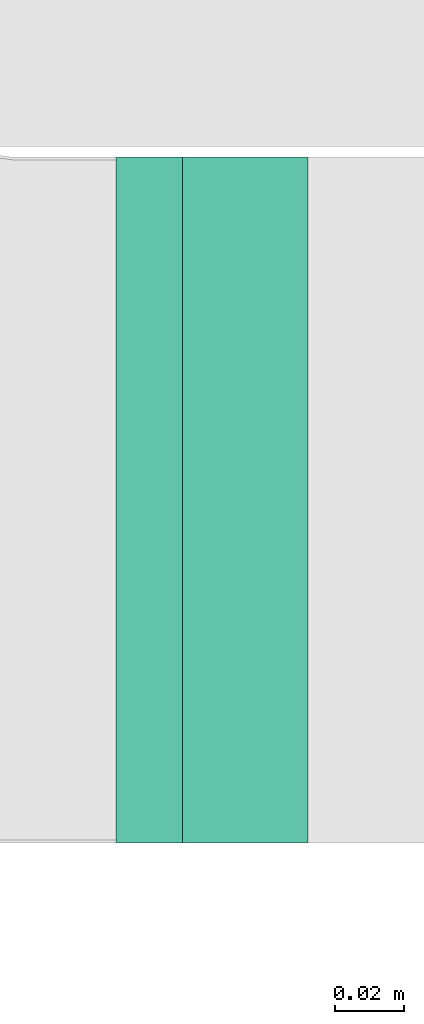
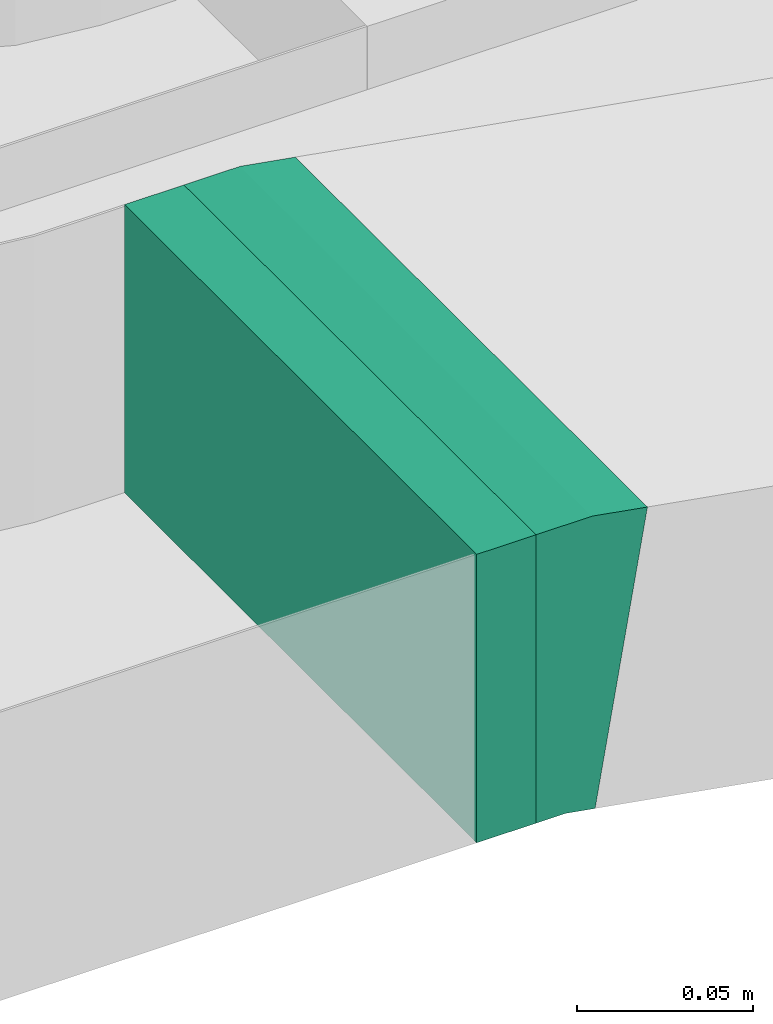
# One storey, part 14 of 38: 1 flow fitting, 1 flow segment.
"""IFC2X3 building model written with IfcOpenShell, lengths in millimetres."""

from ifc_helpers import new_model, entity, si_unit, converted_unit, derived_unit, direction, frame, frame_2d, origin, place, context, subcontext, project, spatial, rectangle, extrude, faceted_brep, source, transform, mapped, material, type_object, type_shapes, element, save


model = new_model("IFC2X3")

# Units and contexts
model_context = context("Model", 3, precision=0.01, world=origin(), true_north=direction((6.12303176911189e-17, 1.0)))
body_context = subcontext(model_context, "Body", "Model", "MODEL_VIEW")
ifc_project = project(units=[si_unit("LENGTHUNIT", "METRE", prefix="MILLI"), si_unit("AREAUNIT", "SQUARE_METRE"), si_unit("VOLUMEUNIT", "CUBIC_METRE"), converted_unit("PLANEANGLEUNIT", "DEGREE", entity("IfcRatioMeasure", 0.0174532925199433), si_unit("PLANEANGLEUNIT", "RADIAN"), dimensions=[0, 0, 0, 0, 0, 0, 0]), si_unit("MASSUNIT", "GRAM", prefix="KILO"), derived_unit("MASSDENSITYUNIT", [(si_unit("MASSUNIT", "GRAM", prefix="KILO"), 1), (si_unit("LENGTHUNIT", "METRE"), -3)]), derived_unit("MOMENTOFINERTIAUNIT", [(si_unit("LENGTHUNIT", "METRE"), 4)]), si_unit("TIMEUNIT", "SECOND"), si_unit("FREQUENCYUNIT", "HERTZ"), si_unit("THERMODYNAMICTEMPERATUREUNIT", "DEGREE_CELSIUS"), derived_unit("THERMALTRANSMITTANCEUNIT", [(si_unit("MASSUNIT", "GRAM", prefix="KILO"), 1), (si_unit("THERMODYNAMICTEMPERATUREUNIT", "KELVIN"), -1), (si_unit("TIMEUNIT", "SECOND"), -3)]), derived_unit("VOLUMETRICFLOWRATEUNIT", [(si_unit("LENGTHUNIT", "METRE"), 3), (si_unit("TIMEUNIT", "SECOND"), -1)]), derived_unit("MASSFLOWRATEUNIT", [(si_unit("MASSUNIT", "GRAM", prefix="KILO"), 1), (si_unit("TIMEUNIT", "SECOND"), -1)]), derived_unit("ROTATIONALFREQUENCYUNIT", [(si_unit("TIMEUNIT", "SECOND"), -1)]), si_unit("ELECTRICCURRENTUNIT", "AMPERE"), si_unit("ELECTRICVOLTAGEUNIT", "VOLT"), si_unit("POWERUNIT", "WATT"), si_unit("FORCEUNIT", "NEWTON", prefix="KILO"), si_unit("ILLUMINANCEUNIT", "LUX"), si_unit("LUMINOUSFLUXUNIT", "LUMEN"), si_unit("LUMINOUSINTENSITYUNIT", "CANDELA"), derived_unit("USERDEFINED", [(si_unit("MASSUNIT", "GRAM", prefix="KILO"), -1), (si_unit("LENGTHUNIT", "METRE"), -2), (si_unit("TIMEUNIT", "SECOND"), 3), (si_unit("LUMINOUSFLUXUNIT", "LUMEN"), 1)]), derived_unit("LINEARVELOCITYUNIT", [(si_unit("LENGTHUNIT", "METRE"), 1), (si_unit("TIMEUNIT", "SECOND"), -1)]), si_unit("PRESSUREUNIT", "PASCAL"), derived_unit("USERDEFINED", [(si_unit("LENGTHUNIT", "METRE"), -2), (si_unit("MASSUNIT", "GRAM", prefix="KILO"), 1), (si_unit("TIMEUNIT", "SECOND"), -2)]), derived_unit("LINEARFORCEUNIT", [(si_unit("MASSUNIT", "GRAM", prefix="KILO"), 1), (si_unit("LENGTHUNIT", "METRE"), 1), (si_unit("TIMEUNIT", "SECOND"), -2), (si_unit("LENGTHUNIT", "METRE"), -1)]), derived_unit("PLANARFORCEUNIT", [(si_unit("MASSUNIT", "GRAM", prefix="KILO"), 1), (si_unit("LENGTHUNIT", "METRE"), 1), (si_unit("TIMEUNIT", "SECOND"), -2), (si_unit("LENGTHUNIT", "METRE"), -2)])], contexts=[model_context])

# Site, building, storey
site_placement = place(None, frame((0.0, -0.00077364408347762, 0.0)))
site = spatial("IfcSite", under=ifc_project, at=site_placement, CompositionType="ELEMENT")
building_placement = place(site_placement, origin())
building = spatial("IfcBuilding", under=site, at=building_placement, CompositionType="ELEMENT")
storey_placement = place(building_placement, frame((0.0, 0.0, 4200.0)))
storey = spatial("IfcBuildingStorey", under=building, at=storey_placement, CompositionType="ELEMENT", Elevation=4200.0)

# Flow segment
cable_carrier_segment_type = type_object("IfcCableCarrierSegmentType", PredefinedType="CABLETRAYSEGMENT")
flow_segment_placement = place(storey_placement, frame((14813.5407015969, 11443.7857236441, 2904.05791329438)))
element("IfcFlowSegment", 1, at=flow_segment_placement, inside=storey, type_object=cable_carrier_segment_type, context=body_context, shape_type="SweptSolid", body=[
    extrude(rectangle(XDim=19.4517341104529, YDim=200.000000000002, at=frame_2d((1.08357767203415e-12, 0.0), x_axis=(1.0, 0.0))), frame((9.72586705522754, 100.0, 0.0)), (0.0, 0.0, 1.0), 99.9999999999989),
])

# Flow fitting
ifc_material = material()
cable_carrier_fitting_type = type_object("IfcCableCarrierFittingType", PredefinedType="NOTDEFINED", material=ifc_material)
shared_shape = source(origin(), body_context, "Body", "Brep", [
    faceted_brep([(-14.083666894315, -50.0, 100.0), (-14.0836668943147, 50.0, 100.0), (-14.0836668943147, 50.0, 97.4600000101635), (-14.083666894315, -47.4600000101599, 97.4600000101635), (-14.083666894315, -47.4600000101599, -97.4600000101564), (-14.0836668943147, 50.0, -97.4600000101564), (-14.0836668943147, 50.0, -100.0), (-14.083666894315, -50.0, -100.0), (22.4612696054003, -46.8384568586927, 100.0), (22.4612696054003, -46.8384568586927, -100.0), (5.28757782509931, 51.6758279462797, -100.0), (5.28757782509931, 51.6758279462797, -97.4600000101564), (22.0250578359255, -44.3361940346554, -97.4600000101564), (22.0250578359255, -44.3361940346554, 97.4600000101635), (5.28757782509931, 51.6758279462797, 97.4600000101635), (5.2875778250993, 51.6758279462798, 100.0), (4.32555566395999, -50.0, 100.0), (-4.32555566395925, 50.0, 100.0), (-4.32555566395925, 50.0, 97.4600000101635), (4.10581743710975, -47.46000001016, 97.4600000101635), (4.10581743710975, -47.46000001016, -97.4600000101564), (-4.32555566395925, 50.0, -97.4600000101564), (-4.32555566395925, 50.0, -100.0), (4.32555566395995, -50.0, -100.0)], [[[0, 1, 2, 3, 4, 5, 6, 7]], [[8, 9, 10, 11, 12, 13, 14, 15]], [[1, 0, 16, 8, 15, 17]], [[2, 1, 17, 18]], [[3, 2, 18, 14, 13, 19]], [[4, 3, 19, 20]], [[5, 4, 20, 12, 11, 21]], [[6, 5, 21, 22]], [[7, 6, 22, 10, 9, 23]], [[0, 7, 23, 16]], [[18, 17, 15, 14]], [[20, 19, 13, 12]], [[22, 21, 11, 10]], [[16, 23, 9, 8]]]),
])
type_shapes(cable_carrier_fitting_type, [shared_shape])
flow_fitting_placement = place(storey_placement, frame((14847.0761026016, 11543.7857236441, 2954.05791329438), z_axis=(0.0, 1.0, 0.0), x_axis=(1.0, 0.0, 0.0)))
element("IfcFlowFitting", 2, at=flow_fitting_placement, inside=storey, type_object=cable_carrier_fitting_type, material=ifc_material, context=body_context, shape_type="MappedRepresentation", body=[
    mapped(shared_shape, transform((0.0, 0.0, 0.0), scale=1.0)),
])

save(model, "model.ifc")
